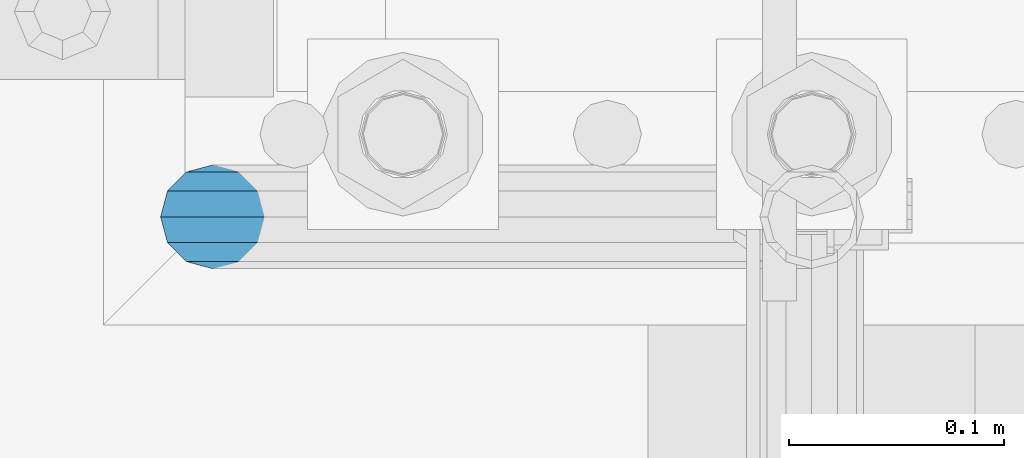
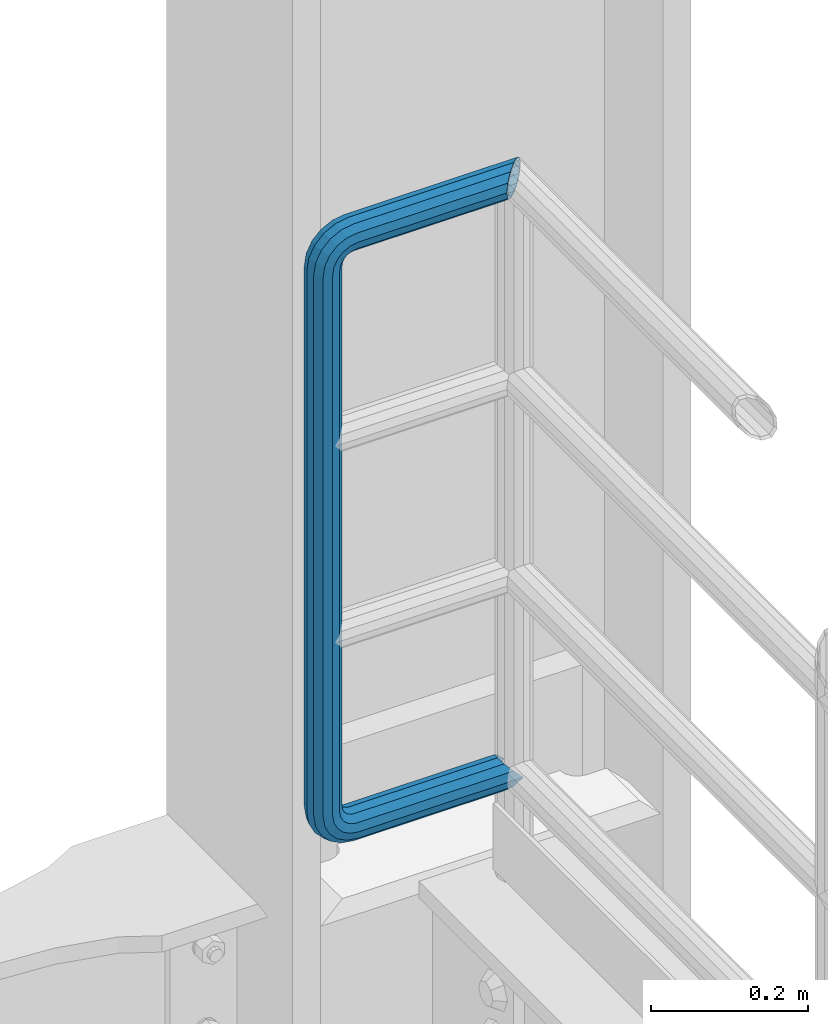
# One storey, part 1071 of 1876: 1 beam, 1 element without a shape of its own.
"""IFC2X3 building model written with IfcOpenShell, lengths in millimetres."""

from ifc_helpers import new_model, si_unit, frame, origin_with_axes, place, context, subcontext, project, spatial, faceted_brep, material, type_object, element, aggregate, save


model = new_model("IFC2X3")

# Units and contexts
model_context = context("Model", 3, precision=1e-05, world=origin_with_axes())
body_context = subcontext(model_context, "Body", "Model", "MODEL_VIEW")
ifc_project = project(units=[si_unit("LENGTHUNIT", "METRE", prefix="MILLI"), si_unit("AREAUNIT", "SQUARE_METRE"), si_unit("VOLUMEUNIT", "CUBIC_METRE"), si_unit("MASSUNIT", "GRAM", prefix="KILO"), si_unit("TIMEUNIT", "SECOND"), si_unit("PLANEANGLEUNIT", "RADIAN"), si_unit("SOLIDANGLEUNIT", "STERADIAN"), si_unit("THERMODYNAMICTEMPERATUREUNIT", "DEGREE_CELSIUS"), si_unit("LUMINOUSINTENSITYUNIT", "LUMEN")], contexts=[model_context])

# Site, building, storey
site_placement = place(None, origin_with_axes())
site = spatial("IfcSite", under=ifc_project, at=site_placement, CompositionType="ELEMENT")
building_placement = place(site_placement, origin_with_axes())
building = spatial("IfcBuilding", under=site, at=building_placement, Name="Undefined", CompositionType="ELEMENT")
storey_placement = place(building_placement, origin_with_axes())
storey = spatial("IfcBuildingStorey", under=building, at=storey_placement, Name="Undefined", CompositionType="ELEMENT", Elevation=0.0)

# Assembly, beam
assembly_placement = place(storey_placement, origin_with_axes())
assembly = element("IfcElementAssembly", 1, at=assembly_placement, inside=storey, Name="RAIL", AssemblyPlace="NOTDEFINED", PredefinedType="RIGID_FRAME")
ifc_material = material()
beam_type = type_object("IfcBeamType", Name="PIPE1-1/2SCH40", PredefinedType="NOTDEFINED")
beam_placement = place(assembly_placement, frame((7619.99999999999, 13499.7063, 19059.525), z_axis=(0.0, 0.0, 1.0), x_axis=(-1.0, 0.0, 0.0)))
beam = element("IfcBeam", 2, at=beam_placement, type_object=beam_type, material=ifc_material, Name="RAIL", ObjectType="PIPE1-1/2SCH40", context=body_context, shape_type="Brep", body=[
    faceted_brep([(1.20714750983051e-12, 24.1299999999974, -914.399963378906), (12.0650000000014, 20.8971929933159, -926.464963378905), (12.0650000000014, 20.8971929933177, -902.334963378908), (12.0650000000014, -20.8971929933195, -902.334963378908), (12.0650000000014, -20.8971929933195, -926.464963378905), (1.52133659548828e-12, -24.130000000001, -914.399963378906), (20.8971929933199, -12.0650000000023, -893.502770385589), (20.8971929933199, -12.0650000000005, -898.533841947723), (15.2545715621378, -17.7076214311819, -904.176463378906), (12.5151929933181, -20.4470000000019, -914.399963378906), (15.2545715621376, -17.7076214311819, -924.623463378906), (20.8971929933199, -12.0650000000005, -930.26608481009), (20.8971929933199, -12.0650000000023, -935.297156372224), (24.1300000000014, -1.81898940354586e-12, -934.846963378906), (24.1300000000014, -1.81898940354586e-12, -938.529963378907), (21.3906214311813, -10.2235000000019, -932.107584810088), (21.3906214311823, 10.2234999999982, -932.107584810088), (20.8971929933199, 12.0650000000005, -930.266084810086), (20.8971929933199, 12.0649999999987, -935.297156372224), (15.2545715621413, 17.7076214311783, -924.623463378906), (12.5151929933216, 20.4469999999983, -914.399963378906), (15.2545715621411, 17.7076214311783, -904.176463378906), (20.8971929933199, 12.0650000000005, -898.533841947727), (20.8971929933199, 12.0649999999987, -893.502770385589), (21.3906214311822, 10.2234999999982, -896.692341947724), (24.1300000000014, 0.0, -893.952963378906), (24.1300000000014, 0.0, -890.269963378905), (21.3906214311814, -10.2235000000019, -896.692341947724), (241.299995422363, 20.8971929933177, -12.0649999999987), (241.299995422363, 24.1299999999992, 0.0), (253.073542436527, 24.1299999999992, -1.86474665447167), (249.345252399393, 20.8971929933177, -13.3392435235728), (241.299995422363, 12.0650000000005, -20.8971929933177), (246.615954666858, 12.0650000000005, -21.7391582230448), (241.299995422363, 0.0, -24.130000000001), (245.616962362259, 0.0, -24.8137403926739), (241.299995422363, -12.0650000000005, -20.8971929933177), (246.615954666858, -12.0650000000005, -21.7391582230448), (241.299995422363, -20.8971929933177, -12.0649999999987), (249.345252399393, -20.8971929933177, -13.3392435235728), (241.299995422363, -24.1299999999992, 0.0), (253.073542436527, -24.1299999999992, -1.86474665447167), (241.299995422363, -20.8971929933177, 12.0649999999987), (256.801832473661, -20.8971929933177, 9.60975021462946), (241.299995422363, -12.0650000000005, 20.8971929933177), (259.531130206197, -12.0650000000005, 18.0096649141014), (241.299995422363, 0.0, 24.130000000001), (260.530122510796, 0.0, 21.084247083727), (241.299995422363, 12.0650000000005, 20.8971929933177), (259.531130206197, 12.0650000000005, 18.0096649141014), (241.299995422363, 20.8971929933177, 12.0649999999987), (256.801832473661, 20.8971929933177, 9.60975021462946), (291.464993896486, -20.8971929933177, -38.0999984741211), (279.399993896484, -24.1299999999992, -38.0999984741211), (279.399993896484, -24.1299999999992, -876.299964904785), (291.464993896484, -20.8971929933177, -876.299964904785), (267.334993896485, -20.8971929933177, -38.0999984741211), (267.334993896484, -20.8971929933177, -876.299964904785), (258.502800903167, -12.0650000000005, -38.0999984741211), (258.502800903166, -12.0650000000005, -876.299964904785), (255.269993896485, 0.0, -38.0999984741211), (255.269993896484, 0.0, -876.299964904785), (258.502800903167, 12.0650000000005, -38.0999984741211), (258.502800903166, 12.0650000000005, -876.299964904785), (267.334993896485, 20.8971929933177, -38.0999984741211), (267.334993896484, 20.8971929933177, -876.299964904785), (279.399993896485, 24.1299999999992, -38.0999984741211), (279.399993896484, 24.1299999999992, -876.299964904785), (291.464993896486, 20.8971929933177, -38.0999984741211), (291.464993896484, 20.8971929933177, -876.299964904785), (300.297186889804, 12.0650000000005, -38.0999984741211), (300.297186889803, 12.0650000000005, -876.299964904785), (303.529993896486, 0.0, -38.0999984741211), (303.529993896484, 0.0, -876.299964904785), (300.297186889804, -12.0650000000005, -38.0999984741211), (300.297186889803, -12.0650000000005, -876.299964904785), (297.409658810584, -12.0650000000005, -894.531099688622), (300.484240980214, 0.0, -895.53009199322), (297.409658810584, 12.0650000000005, -894.531099688622), (289.009744111112, 20.8971929933177, -891.801801956084), (277.535247242011, 24.1299999999992, -888.073511918952), (266.06075037291, 20.8971929933177, -884.345221881817), (257.660835673438, 12.0650000000005, -881.615924149282), (254.586253503809, 0.0, -880.616931844681), (257.660835673438, -12.0650000000005, -881.615924149282), (266.06075037291, -20.8971929933177, -884.345221881817), (277.535247242011, -24.130000000001, -888.073511918952), (289.009744111112, -20.8971929933195, -891.801801956084), (241.299995422363, -20.8971929933195, -902.334963378908), (241.299995422363, -12.0650000000005, -893.502770385589), (241.299995422363, -24.130000000001, -914.399963378906), (241.299995422364, -20.8971929933195, -926.464963378909), (241.299995422364, -12.0650000000005, -935.297156372228), (241.299995422364, -1.81898940354586e-12, -938.529963378911), (241.299995422364, 12.0649999999987, -935.297156372228), (241.299995422364, 20.8971929933177, -926.464963378909), (241.299995422364, 24.1299999999992, -914.39996337891), (241.299995422363, 20.8971929933177, -902.334963378908), (241.299995422363, 12.0649999999987, -893.502770385589), (241.299995422363, 0.0, -890.269963378909), (245.61696236226, 0.0, -889.586222986232), (246.615954666859, -12.0650000000005, -892.660805155861), (246.615954666859, 12.0649999999987, -892.660805155861), (249.345252399395, 20.8971929933177, -901.060719855333), (253.07354243653, 24.1299999999992, -912.535216724435), (256.801832473666, 20.8971929933177, -924.009713593536), (259.531130206202, 12.0649999999987, -932.409628293008), (260.530122510801, 0.0, -935.484210462637), (259.531130206201, -12.0650000000005, -932.409628293008), (256.801832473666, -20.8971929933195, -924.009713593536), (253.07354243653, -24.130000000001, -912.535216724435), (249.345252399395, -20.8971929933195, -901.060719855333), (251.411550782037, -12.0650000000005, -890.21732688968), (256.602983568912, -20.8971929933195, -897.362721118872), (249.511354500001, 0.0, -887.601931081743), (251.411550782037, 12.0650000000005, -890.21732688968), (256.602983568912, 20.8971929933177, -897.362721118872), (263.694612637823, 24.1299999999992, -907.123511156005), (270.786241706733, 20.8971929933177, -916.884301193139), (275.977674493594, 12.0649999999987, -924.029695422345), (277.877870775644, 0.0, -926.645091230272), (275.977674493608, -12.0650000000005, -924.029695422334), (270.786241706733, -20.8971929933195, -916.884301193139), (263.694612637823, -24.130000000001, -907.123511156005), (262.362751636451, -20.8971929933195, -891.602953051333), (272.123541673585, -24.130000000001, -898.694582120243), (255.217357407258, -12.0650000000005, -886.411520264461), (252.601961599318, 0.0, -884.511323982424), (255.217357407258, 12.0650000000005, -886.411520264461), (262.362751636451, 20.8971929933177, -891.602953051333), (272.123541673585, 24.1299999999992, -898.694582120243), (281.884331710718, 20.8971929933177, -905.786211189152), (289.029725939912, 12.0650000000005, -910.977643976028), (291.645121747852, 0.0, -912.877840258065), (289.029725939912, -12.0650000000005, -910.977643976028), (281.884331710718, -20.8971929933195, -905.786211189152), (289.009744111112, -20.8971929933177, -22.5981614228222), (297.409658810584, -12.0650000000005, -19.8688636902843), (277.535247242011, -24.1299999999992, -26.3264514599541), (266.060750372911, -20.8971929933177, -30.0547414970897), (257.660835673439, -12.0650000000005, -32.7840392296275), (254.58625350381, 0.0, -33.7830315342253), (257.660835673439, 12.0650000000005, -32.7840392296275), (266.060750372911, 20.8971929933177, -30.0547414970897), (277.535247242011, 24.1299999999992, -26.3264514599541), (289.009744111112, 20.8971929933177, -22.5981614228222), (297.409658810584, 12.0650000000005, -19.8688636902843), (300.484240980213, 0.0, -18.8698713856866), (289.029725939909, -12.0650000000005, -3.42231940287456), (291.645121747848, 0.0, -1.52212312084157), (281.884331710716, -20.8971929933177, -8.61375218975081), (272.123541673583, -24.1299999999992, -15.7053812586601), (262.362751636451, -20.8971929933177, -22.7970103275729), (255.217357407257, -12.0650000000005, -27.9884431144455), (252.601961599318, 0.0, -29.8886393964822), (255.217357407257, 12.0650000000005, -27.9884431144455), (262.362751636451, 20.8971929933177, -22.7970103275729), (272.123541673583, 24.1299999999992, -15.7053812586601), (281.884331710716, 20.8971929933177, -8.61375218975081), (289.029725939909, 12.0650000000005, -3.42231940287456), (277.877870775642, 0.0, 12.2451278513654), (275.977674493607, 12.0650000000005, 9.62973204342416), (275.977674493607, -12.0650000000005, 9.62973204342416), (270.786241706732, -20.8971929933177, 2.48433781423228), (263.694612637822, -24.1299999999992, -7.27645222290084), (256.602983568912, -20.8971929933177, -17.037242260034), (251.411550782037, -12.0650000000005, -24.1826364892258), (249.511354500002, 0.0, -26.7980322971671), (251.411550782037, 12.0650000000005, -24.1826364892258), (256.602983568912, 20.8971929933177, -17.037242260034), (263.694612637822, 24.1299999999992, -7.27645222290084), (270.786241706732, 20.8971929933177, 2.48433781423228), (24.1300000000047, 24.1299999999992, 0.0), (20.8971929933232, 20.8971929933177, 12.0649999999987), (12.0650000000041, 12.0650000000005, 20.8971929933177), (-1.45519152283669e-11, 0.0, 24.130000000001), (-12.0649999999951, -12.0650000000005, 20.8971929933177), (-20.8971929933141, -20.8971929933177, 12.0649999999987), (0.0, -24.1299999999992, 0.0), (-24.1299999999956, -24.1299999999992, 0.0), (-12.0650000000096, -20.8971929933177, -12.0649999999987), (12.0650000000064, -20.8971929933177, -12.0649999999987), (-20.8971929933141, -20.8971929933177, -12.0649999999987), (-12.0649999999951, -12.0650000000005, -20.8971929933177), (20.8971929933249, -12.0650000000005, -20.8971929933177), (-16.481093238739, -16.4810932387427, -16.4810997545756), (24.1300000000063, 0.0, -24.130000000001), (-1.45519152283669e-11, 0.0, -24.130000000001), (20.8971929933249, 12.0650000000005, -20.8971929933177), (12.0650000000041, 12.0650000000005, -20.8971929933177), (20.8971929933232, 20.8971929933177, -12.0649999999987), (16.481099754581, 16.4810997545774, -16.4810932387409), (241.299995422363, -17.7076214311801, 10.2235000000001), (241.299995422363, -20.4470000000001, 0.0), (-20.4469999999956, -20.4470000000001, 0.0), (-17.7076214311755, -17.7076214311801, 10.2235000000001), (241.299995422363, -17.7076214311801, -10.2235000000001), (-17.7076214311755, -17.7076214311801, -10.2235000000001), (241.299995422363, -10.2235000000001, -17.7076214311819), (-10.2234999999955, -10.2235000000001, -17.7076214311819), (241.299995422363, 0.0, -20.4470000000001), (-1.45519152283669e-11, 0.0, -20.4470000000001), (241.299995422363, 10.2235000000001, -17.7076214311819), (10.2235000000046, 10.2235000000001, -17.7076214311819), (241.299995422363, 17.7076214311801, -10.2235000000001), (17.7076214311846, 17.7076214311801, -10.2235000000001), (241.299995422363, 20.4470000000001, 0.0), (20.4470000000047, 20.4470000000001, 0.0), (241.299995422363, 0.0, 20.4470000000001), (241.299995422363, -10.2235000000001, 17.7076214311819), (-10.2234999999955, -10.2235000000001, 17.7076214311819), (-1.45519152283669e-11, 0.0, 20.4470000000001), (241.299995422363, 10.2235000000001, 17.7076214311819), (10.2235000000046, 10.2235000000001, 17.7076214311819), (241.299995422363, 17.7076214311801, 10.2235000000001), (17.7076214311846, 17.7076214311801, 10.2235000000001), (258.545498388721, -10.2235000000001, 14.9762020957387), (256.23277767852, -17.7076214311801, 7.85837963987069), (253.073542436527, -20.4470000000001, -1.86474665447167), (249.914307194535, -17.7076214311801, -11.5878729488177), (247.601586484334, -10.2235000000001, -18.7056954046857), (246.755071952542, 0.0, -21.31099924316), (247.601586484334, 10.2235000000001, -18.7056954046857), (249.914307194535, 17.7076214311801, -11.5878729488177), (253.073542436527, 20.4470000000001, -1.86474665447167), (256.23277767852, 17.7076214311801, 7.85837963987069), (258.545498388721, 10.2235000000001, 14.9762020957387), (259.392012920513, 0.0, 17.5815059342131), (275.713057691449, 0.0, 9.26551826108334), (274.10289136825, -10.2235000000001, 7.04931444488102), (274.10289136825, 10.2235000000001, 7.04931444488102), (269.703835164635, 17.7076214311801, 0.994533019089431), (263.694612637822, 20.4470000000001, -7.27645222290084), (257.685390111009, 17.7076214311801, -15.5474374648911), (253.286333907394, 10.2235000000001, -21.6022188906827), (251.676167584195, 0.0, -23.818422706885), (253.286333907394, -10.2235000000001, -21.6022188906827), (257.685390111009, -17.7076214311801, -15.5474374648911), (263.694612637822, -20.4470000000001, -7.27645222290084), (269.703835164635, -17.7076214311801, 0.994533019089431), (286.449308341364, -10.2235000000001, -5.29710252823133), (280.394526915574, -17.7076214311801, -9.69615873184739), (288.665512157566, 0.0, -3.68693620503473), (286.449308341364, 10.2235000000001, -5.29710252823133), (280.394526915574, 17.7076214311801, -9.69615873184739), (272.123541673583, 20.4470000000001, -15.7053812586601), (263.852556431592, 17.7076214311801, -21.7146037854764), (257.797775005802, 10.2235000000001, -26.1136599890888), (255.581571189601, 0.0, -27.723826312289), (257.797775005802, -10.2235000000001, -26.1136599890888), (263.852556431592, -17.7076214311801, -21.7146037854764), (272.123541673583, -20.4470000000001, -15.7053812586601), (287.258373536355, -17.7076214311801, -23.1672162179639), (277.535247242011, -20.4470000000001, -26.3264514599541), (294.376195992223, -10.2235000000001, -20.8544955077632), (296.981499830698, 0.0, -20.00798097597), (294.376195992223, 10.2235000000001, -20.8544955077632), (287.258373536355, 17.7076214311801, -23.1672162179639), (277.535247242011, 20.4470000000001, -26.3264514599541), (267.812120947668, 17.7076214311801, -29.485686701948), (260.6942984918, 10.2235000000001, -31.7984074121487), (258.088994653325, 0.0, -32.6449219439419), (260.6942984918, -10.2235000000001, -31.7984074121487), (267.812120947668, -17.7076214311801, -29.485686701948), (279.399993896484, -20.4470000000001, -38.0999984741211), (269.176493896485, -17.7076214311801, -38.0999984741211), (289.623493896486, -17.7076214311801, -38.0999984741211), (297.107615327666, -10.2235000000001, -38.0999984741211), (299.846993896486, 0.0, -38.0999984741211), (297.107615327666, 10.2235000000001, -38.0999984741211), (289.623493896486, 17.7076214311801, -38.0999984741211), (279.399993896485, 20.4470000000001, -38.0999984741211), (269.176493896485, 17.7076214311801, -38.0999984741211), (261.692372465305, 10.2235000000001, -38.0999984741211), (258.952993896485, 0.0, -38.0999984741211), (261.692372465305, -10.2235000000001, -38.0999984741211), (269.176493896484, -17.7076214311801, -876.299964904785), (261.692372465304, -10.2235000000001, -876.299964904785), (258.952993896484, 0.0, -876.299964904785), (261.692372465304, 10.2235000000001, -876.299964904785), (269.176493896484, 17.7076214311801, -876.299964904785), (279.399993896484, 20.4470000000001, -876.299964904785), (289.623493896484, 17.7076214311801, -876.299964904785), (297.107615327665, 10.2235000000001, -876.299964904785), (299.846993896484, 0.0, -876.299964904785), (297.107615327665, -10.2235000000001, -876.299964904785), (289.623493896484, -17.7076214311801, -876.299964904785), (279.399993896484, -20.4470000000001, -876.299964904785), (277.535247242011, -20.4470000000001, -888.073511918952), (267.812120947667, -17.7076214311801, -884.914276676958), (260.694298491799, -10.2235000000001, -882.601555966758), (258.088994653324, 0.0, -881.755041434964), (260.694298491799, 10.2235000000001, -882.601555966758), (267.812120947668, 17.7076214311801, -884.914276676958), (277.535247242011, 20.4470000000001, -888.073511918952), (287.258373536355, 17.7076214311801, -891.232747160942), (294.376195992223, 10.2235000000001, -893.545467871143), (296.981499830699, 0.0, -894.391982402936), (294.376195992223, -10.2235000000001, -893.545467871143), (287.258373536355, -17.7076214311801, -891.232747160942), (280.394526915577, -17.7076214311801, -904.703804647055), (272.123541673585, -20.4470000000001, -898.694582120243), (286.449308341367, -10.2235000000001, -909.102860850671), (288.665512157569, 0.0, -910.713027173868), (286.449308341367, 10.2235000000001, -909.102860850671), (280.394526915577, 17.7076214311801, -904.703804647055), (272.123541673585, 20.4470000000001, -898.694582120243), (263.852556431593, 17.7076214311801, -892.68535959343), (257.797775005802, 10.2235000000001, -888.286303389817), (255.581571189601, 0.0, -886.676137066617), (257.797775005802, -10.2235000000001, -888.286303389817), (263.852556431593, -17.7076214311801, -892.68535959343), (263.694612637823, -20.4470000000001, -907.123511156005), (257.685390111009, -17.7076214311801, -898.852525914015), (269.703835164636, -17.7076214311801, -915.394496397999), (274.102891368238, -10.2235000000001, -921.449277823798), (275.71305769145, 0.0, -923.66548163999), (274.102891368251, 10.2235000000001, -921.449277823787), (269.703835164636, 17.7076214311801, -915.394496397999), (263.694612637823, 20.4470000000001, -907.123511156005), (257.685390111009, 17.7076214311801, -898.852525914015), (253.286333907394, 10.2235000000001, -892.797744488227), (251.676167584195, 0.0, -890.581540672025), (253.286333907394, -10.2235000000001, -892.797744488227), (249.914307194537, -17.7076214311801, -902.812090430092), (247.601586484335, -10.2235000000001, -895.694267974224), (253.07354243653, -20.4470000000001, -912.535216724435), (256.232777678524, -17.7076214311819, -922.258343018777), (258.545498388725, -10.2235000000001, -929.376165474645), (259.392012920517, 0.0, -931.981469313119), (258.545498388725, 10.2235000000001, -929.376165474645), (256.232777678524, 17.7076214311801, -922.258343018777), (253.07354243653, 20.4470000000001, -912.535216724435), (249.914307194537, 17.7076214311801, -902.812090430092), (247.601586484335, 10.2235000000001, -895.694267974224), (246.755071952543, 0.0, -893.088964135746), (241.299995422363, -10.2235000000001, -896.692341947728), (241.299995422363, 0.0, -893.95296337891), (241.299995422363, -17.7076214311819, -904.17646337891), (241.299995422363, -20.4470000000001, -914.399963378906), (241.299995422364, -17.7076214311819, -924.62346337891), (241.299995422364, -10.2235000000001, -932.107584810088), (241.299995422364, -1.81898940354586e-12, -934.84696337891), (241.299995422364, 10.2234999999982, -932.107584810088), (241.299995422364, 17.7076214311801, -924.62346337891), (241.299995422364, 20.4470000000001, -914.39996337891), (241.299995422363, 17.7076214311801, -904.17646337891), (241.299995422363, 10.2235000000001, -896.692341947728)], [[[0, 1, 2]], [[3, 4, 5]], [[6, 7, 8, 9, 10, 11, 12, 4, 3]], [[13, 14, 12, 11, 15]], [[16, 17, 18, 14, 13]], [[2, 1, 18, 17, 19, 20, 21, 22, 23]], [[23, 22, 24, 25, 26]], [[26, 25, 27, 7, 6]], [[28, 29, 30, 31]], [[32, 28, 31, 33]], [[34, 32, 33, 35]], [[36, 34, 35, 37]], [[38, 36, 37, 39]], [[40, 38, 39, 41]], [[42, 40, 41, 43]], [[44, 42, 43, 45]], [[46, 44, 45, 47]], [[48, 46, 47, 49]], [[50, 48, 49, 51]], [[52, 53, 54, 55]], [[53, 56, 57, 54]], [[56, 58, 59, 57]], [[58, 60, 61, 59]], [[60, 62, 63, 61]], [[62, 64, 65, 63]], [[64, 66, 67, 65]], [[66, 68, 69, 67]], [[68, 70, 71, 69]], [[70, 72, 73, 71]], [[72, 74, 75, 73]], [[73, 75, 76, 77]], [[71, 73, 77, 78]], [[69, 71, 78, 79]], [[67, 69, 79, 80]], [[65, 67, 80, 81]], [[63, 65, 81, 82]], [[61, 63, 82, 83]], [[59, 61, 83, 84]], [[57, 59, 84, 85]], [[54, 57, 85, 86]], [[55, 54, 86, 87]], [[88, 89, 6, 3]], [[90, 88, 3, 5]], [[91, 90, 5, 4]], [[92, 91, 4, 12]], [[93, 92, 12, 14]], [[94, 93, 14, 18]], [[95, 94, 18, 1]], [[96, 95, 1, 0]], [[97, 96, 0, 2]], [[98, 97, 2, 23]], [[99, 98, 23, 26]], [[89, 99, 26, 6]], [[100, 99, 89, 101]], [[102, 98, 99, 100]], [[103, 97, 98, 102]], [[104, 96, 97, 103]], [[105, 95, 96, 104]], [[106, 94, 95, 105]], [[107, 93, 94, 106]], [[108, 92, 93, 107]], [[109, 91, 92, 108]], [[110, 90, 91, 109]], [[111, 88, 90, 110]], [[101, 89, 88, 111]], [[112, 101, 111, 113]], [[114, 100, 101, 112]], [[115, 102, 100, 114]], [[116, 103, 102, 115]], [[117, 104, 103, 116]], [[118, 105, 104, 117]], [[119, 106, 105, 118]], [[120, 107, 106, 119]], [[121, 108, 107, 120]], [[122, 109, 108, 121]], [[123, 110, 109, 122]], [[113, 111, 110, 123]], [[124, 113, 123, 125]], [[126, 112, 113, 124]], [[127, 114, 112, 126]], [[128, 115, 114, 127]], [[129, 116, 115, 128]], [[130, 117, 116, 129]], [[131, 118, 117, 130]], [[132, 119, 118, 131]], [[133, 120, 119, 132]], [[134, 121, 120, 133]], [[135, 122, 121, 134]], [[125, 123, 122, 135]], [[86, 125, 135, 87]], [[85, 124, 125, 86]], [[84, 126, 124, 85]], [[83, 127, 126, 84]], [[82, 128, 127, 83]], [[81, 129, 128, 82]], [[80, 130, 129, 81]], [[79, 131, 130, 80]], [[78, 132, 131, 79]], [[77, 133, 132, 78]], [[76, 134, 133, 77]], [[87, 135, 134, 76]], [[75, 55, 87, 76]], [[74, 52, 55, 75]], [[136, 52, 74, 137]], [[138, 53, 52, 136]], [[139, 56, 53, 138]], [[140, 58, 56, 139]], [[141, 60, 58, 140]], [[142, 62, 60, 141]], [[143, 64, 62, 142]], [[144, 66, 64, 143]], [[145, 68, 66, 144]], [[146, 70, 68, 145]], [[147, 72, 70, 146]], [[137, 74, 72, 147]], [[148, 137, 147, 149]], [[150, 136, 137, 148]], [[151, 138, 136, 150]], [[152, 139, 138, 151]], [[153, 140, 139, 152]], [[154, 141, 140, 153]], [[155, 142, 141, 154]], [[156, 143, 142, 155]], [[157, 144, 143, 156]], [[158, 145, 144, 157]], [[159, 146, 145, 158]], [[149, 147, 146, 159]], [[160, 149, 159, 161]], [[162, 148, 149, 160]], [[163, 150, 148, 162]], [[164, 151, 150, 163]], [[165, 152, 151, 164]], [[166, 153, 152, 165]], [[167, 154, 153, 166]], [[168, 155, 154, 167]], [[169, 156, 155, 168]], [[170, 157, 156, 169]], [[171, 158, 157, 170]], [[161, 159, 158, 171]], [[49, 161, 171, 51]], [[47, 160, 161, 49]], [[45, 162, 160, 47]], [[43, 163, 162, 45]], [[41, 164, 163, 43]], [[39, 165, 164, 41]], [[37, 166, 165, 39]], [[35, 167, 166, 37]], [[33, 168, 167, 35]], [[31, 169, 168, 33]], [[30, 170, 169, 31]], [[51, 171, 170, 30]], [[29, 50, 51, 30]], [[50, 29, 172, 173]], [[48, 50, 173, 174]], [[46, 48, 174, 175]], [[44, 46, 175, 176]], [[42, 44, 176, 177]], [[178, 40, 42, 177, 179]], [[180, 181, 38, 40, 178, 179, 182]], [[183, 184, 36, 38, 181, 180, 182, 185]], [[186, 34, 36, 184, 183, 187]], [[188, 32, 34, 186, 187, 189]], [[190, 28, 32, 188, 189, 191]], [[29, 28, 190, 172]], [[192, 193, 194, 195]], [[193, 196, 197, 194]], [[196, 198, 199, 197]], [[198, 200, 201, 199]], [[200, 202, 203, 201]], [[202, 204, 205, 203]], [[204, 206, 207, 205]], [[208, 209, 210, 211]], [[212, 208, 211, 213]], [[214, 212, 213, 215]], [[206, 214, 215, 207]], [[191, 189, 187, 183, 185, 182, 179, 177, 176, 175, 174, 173, 172, 190], [213, 211, 210, 195, 194, 197, 199, 201, 203, 205, 207, 215]], [[209, 192, 195, 210]], [[192, 209, 216, 217]], [[193, 192, 217, 218]], [[196, 193, 218, 219]], [[198, 196, 219, 220]], [[200, 198, 220, 221]], [[202, 200, 221, 222]], [[204, 202, 222, 223]], [[206, 204, 223, 224]], [[214, 206, 224, 225]], [[212, 214, 225, 226]], [[208, 212, 226, 227]], [[209, 208, 227, 216]], [[227, 228, 229, 216]], [[226, 230, 228, 227]], [[225, 231, 230, 226]], [[224, 232, 231, 225]], [[223, 233, 232, 224]], [[222, 234, 233, 223]], [[221, 235, 234, 222]], [[220, 236, 235, 221]], [[219, 237, 236, 220]], [[218, 238, 237, 219]], [[217, 239, 238, 218]], [[216, 229, 239, 217]], [[229, 240, 241, 239]], [[228, 242, 240, 229]], [[230, 243, 242, 228]], [[231, 244, 243, 230]], [[232, 245, 244, 231]], [[233, 246, 245, 232]], [[234, 247, 246, 233]], [[235, 248, 247, 234]], [[236, 249, 248, 235]], [[237, 250, 249, 236]], [[238, 251, 250, 237]], [[239, 241, 251, 238]], [[241, 252, 253, 251]], [[240, 254, 252, 241]], [[242, 255, 254, 240]], [[243, 256, 255, 242]], [[244, 257, 256, 243]], [[245, 258, 257, 244]], [[246, 259, 258, 245]], [[247, 260, 259, 246]], [[248, 261, 260, 247]], [[249, 262, 261, 248]], [[250, 263, 262, 249]], [[251, 253, 263, 250]], [[253, 264, 265, 263]], [[252, 266, 264, 253]], [[254, 267, 266, 252]], [[255, 268, 267, 254]], [[256, 269, 268, 255]], [[257, 270, 269, 256]], [[258, 271, 270, 257]], [[259, 272, 271, 258]], [[260, 273, 272, 259]], [[261, 274, 273, 260]], [[262, 275, 274, 261]], [[263, 265, 275, 262]], [[275, 265, 276, 277]], [[274, 275, 277, 278]], [[273, 274, 278, 279]], [[272, 273, 279, 280]], [[271, 272, 280, 281]], [[270, 271, 281, 282]], [[269, 270, 282, 283]], [[268, 269, 283, 284]], [[267, 268, 284, 285]], [[266, 267, 285, 286]], [[264, 266, 286, 287]], [[265, 264, 287, 276]], [[276, 287, 288, 289]], [[277, 276, 289, 290]], [[278, 277, 290, 291]], [[279, 278, 291, 292]], [[280, 279, 292, 293]], [[281, 280, 293, 294]], [[282, 281, 294, 295]], [[283, 282, 295, 296]], [[284, 283, 296, 297]], [[285, 284, 297, 298]], [[286, 285, 298, 299]], [[287, 286, 299, 288]], [[299, 300, 301, 288]], [[298, 302, 300, 299]], [[297, 303, 302, 298]], [[296, 304, 303, 297]], [[295, 305, 304, 296]], [[294, 306, 305, 295]], [[293, 307, 306, 294]], [[292, 308, 307, 293]], [[291, 309, 308, 292]], [[290, 310, 309, 291]], [[289, 311, 310, 290]], [[288, 301, 311, 289]], [[301, 312, 313, 311]], [[300, 314, 312, 301]], [[302, 315, 314, 300]], [[303, 316, 315, 302]], [[304, 317, 316, 303]], [[305, 318, 317, 304]], [[306, 319, 318, 305]], [[307, 320, 319, 306]], [[308, 321, 320, 307]], [[309, 322, 321, 308]], [[310, 323, 322, 309]], [[311, 313, 323, 310]], [[313, 324, 325, 323]], [[312, 326, 324, 313]], [[314, 327, 326, 312]], [[315, 328, 327, 314]], [[316, 329, 328, 315]], [[317, 330, 329, 316]], [[318, 331, 330, 317]], [[319, 332, 331, 318]], [[320, 333, 332, 319]], [[321, 334, 333, 320]], [[322, 335, 334, 321]], [[323, 325, 335, 322]], [[325, 336, 337, 335]], [[324, 338, 336, 325]], [[326, 339, 338, 324]], [[327, 340, 339, 326]], [[328, 341, 340, 327]], [[329, 342, 341, 328]], [[330, 343, 342, 329]], [[331, 344, 343, 330]], [[332, 345, 344, 331]], [[333, 346, 345, 332]], [[334, 347, 346, 333]], [[335, 337, 347, 334]], [[347, 337, 25, 24]], [[21, 346, 347, 24, 22]], [[345, 346, 21, 20]], [[344, 345, 20, 19]], [[343, 344, 19, 17, 16]], [[342, 343, 16, 13]], [[341, 342, 13, 15]], [[10, 340, 341, 15, 11]], [[339, 340, 10, 9]], [[338, 339, 9, 8]], [[336, 338, 8, 7, 27]], [[337, 336, 27, 25]]]),
])
aggregate(assembly, [beam])

save(model, "model.ifc")
